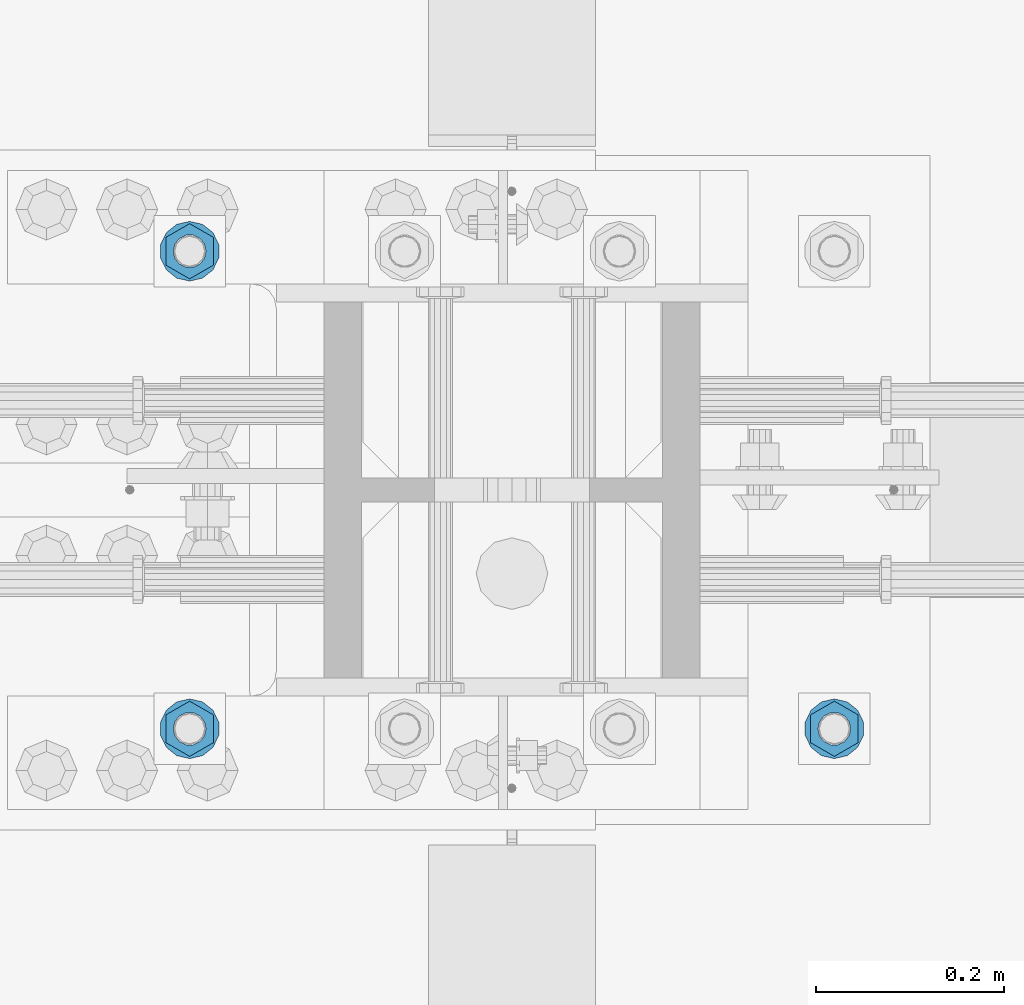
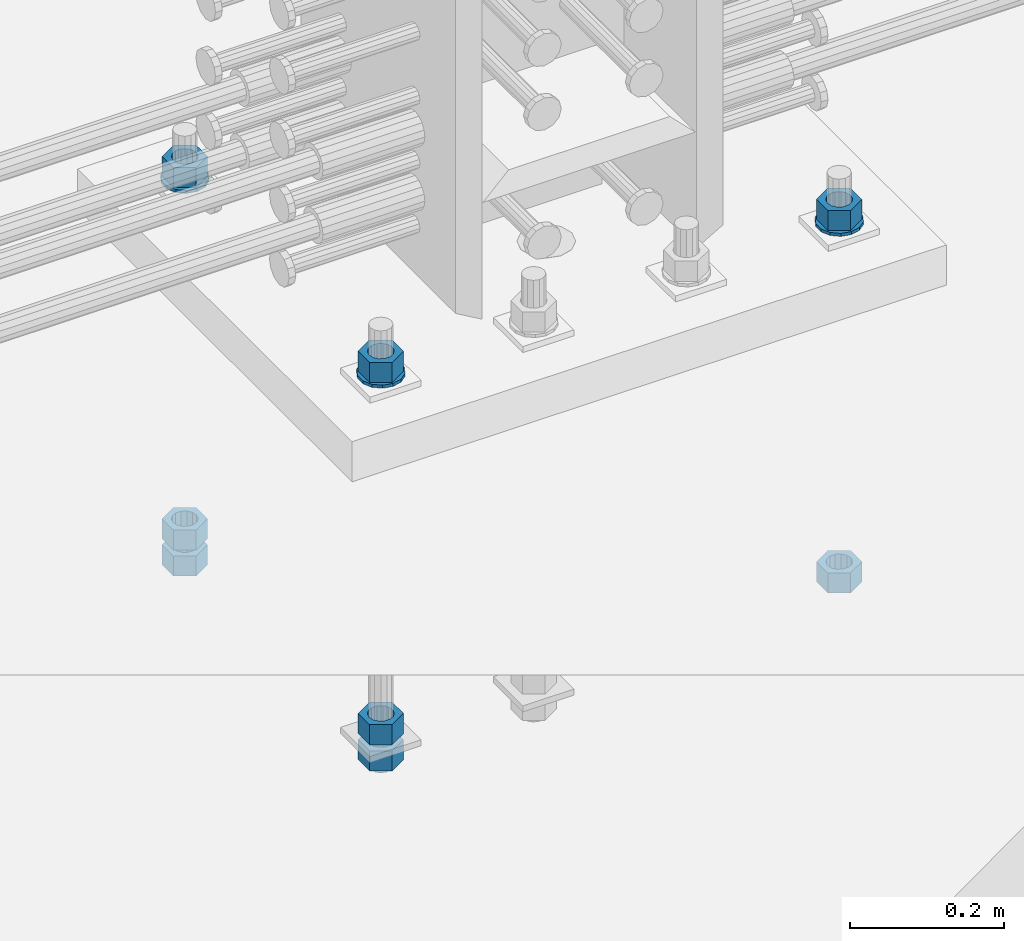
# One storey, part 1003 of 1763: 11 columns, 1 element without a shape of its own.
"""IFC2X3 building model written with IfcOpenShell, lengths in millimetres."""

from ifc_helpers import new_model, si_unit, frame, origin_with_axes, place, context, subcontext, project, spatial, faceted_brep, material, type_object, element, aggregate, save


model = new_model("IFC2X3")

# Units and contexts
model_context = context("Model", 3, precision=1e-05, world=origin_with_axes())
body_context = subcontext(model_context, "Body", "Model", "MODEL_VIEW")
ifc_project = project(units=[si_unit("LENGTHUNIT", "METRE", prefix="MILLI"), si_unit("AREAUNIT", "SQUARE_METRE"), si_unit("VOLUMEUNIT", "CUBIC_METRE"), si_unit("MASSUNIT", "GRAM", prefix="KILO"), si_unit("TIMEUNIT", "SECOND"), si_unit("PLANEANGLEUNIT", "RADIAN"), si_unit("SOLIDANGLEUNIT", "STERADIAN"), si_unit("THERMODYNAMICTEMPERATUREUNIT", "DEGREE_CELSIUS"), si_unit("LUMINOUSINTENSITYUNIT", "LUMEN")], contexts=[model_context])

# Site, building, storey
site_placement = place(None, origin_with_axes())
site = spatial("IfcSite", under=ifc_project, at=site_placement, CompositionType="ELEMENT")
building_placement = place(site_placement, origin_with_axes())
building = spatial("IfcBuilding", under=site, at=building_placement, Name="Undefined", CompositionType="ELEMENT")
storey_placement = place(building_placement, origin_with_axes())
storey = spatial("IfcBuildingStorey", under=building, at=storey_placement, Name="Undefined", CompositionType="ELEMENT", Elevation=0.0)

# Assembly, columns
assembly_placement = place(storey_placement, origin_with_axes())
assembly = element("IfcElementAssembly", 1, at=assembly_placement, inside=storey, Name="TEMPLATE", AssemblyPlace="NOTDEFINED", PredefinedType="RIGID_FRAME")
ifc_material_1 = material(Name="STEEL/A563")
column_type_1 = type_object("IfcColumnType", Name="1-1/4_HEAVY_HEX_NUT", PredefinedType="NOTDEFINED")
column_1_placement = place(assembly_placement, frame((-34606.937273698, 203.199999999951, 3957.6375), z_axis=(1.0, 0.0, 0.0), x_axis=(0.0, 0.0, -1.0)))
column_1 = element("IfcColumn", 2, at=column_1_placement, type_object=column_type_1, material=ifc_material_1, Name="NUT", ObjectType="1-1/4_HEAVY_HEX_NUT", context=body_context, shape_type="Brep", body=[
    faceted_brep([(0.0, -29.3700008392334, 0.0), (0.0, -14.6800003051758, -25.4300003051758), (31.75, -14.6800003051758, -25.4300003051758), (31.75, -29.3700008392334, 0.0), (0.0, 14.6800003051758, -25.4300003051758), (31.75, 14.6800003051758, -25.4300003051758), (0.0, 29.3700008392334, 0.0), (31.75, 29.3700008392334, 0.0), (0.0, 14.6800003051758, 25.4300003051758), (31.75, 14.6800003051758, 25.4300003051758), (0.0, -14.6800003051758, 25.4300003051758), (31.75, -14.6800003051758, 25.4300003051758), (0.0, 0.0, 17.4599990844727), (0.0, 7.57560968776022, 15.730915608714), (31.75, 7.57560968775942, 15.7309156087145), (31.75, 0.0, 17.4599990844727), (0.0, 13.6507769681037, 10.8861313696252), (31.75, 13.6507769681048, 10.8861313696314), (0.0, 17.0222404541215, 3.88521530314756), (31.75, 17.02224045412, 3.88521530315316), (0.0, 17.0222404541215, -3.88521530314756), (31.75, 17.02224045412, -3.88521530315332), (0.0, 13.6507769681037, -10.8861313696252), (31.75, 13.6507769681048, -10.8861313696316), (0.0, 7.57560968776022, -15.730915608714), (31.75, 7.57560968775942, -15.7309156087146), (0.0, 0.0, -17.4599990844727), (31.75, 0.0, -17.4599990844727), (0.0, -7.57560968776022, -15.730915608714), (31.75, -7.57560968775942, -15.7309156087145), (0.0, -13.6507769681037, -10.8861313696252), (31.75, -13.6507769681048, -10.8861313696314), (0.0, -17.0222404541215, -3.88521530314756), (31.75, -17.02224045412, -3.88521530315316), (0.0, -17.0222404541215, 3.88521530314756), (31.75, -17.02224045412, 3.88521530315332), (0.0, -13.6507769681037, 10.8861313696252), (31.75, -13.6507769681048, 10.8861313696316), (0.0, -7.57560968776022, 15.730915608714), (31.75, -7.57560968775942, 15.7309156087146)], [[[0, 1, 2, 3]], [[1, 4, 5, 2]], [[4, 6, 7, 5]], [[6, 8, 9, 7]], [[8, 10, 11, 9]], [[10, 0, 3, 11]], [[12, 13, 14, 15]], [[13, 16, 17, 14]], [[16, 18, 19, 17]], [[18, 20, 21, 19]], [[20, 22, 23, 21]], [[22, 24, 25, 23]], [[24, 26, 27, 25]], [[26, 28, 29, 27]], [[28, 30, 31, 29]], [[30, 32, 33, 31]], [[32, 34, 35, 33]], [[34, 36, 37, 35]], [[36, 38, 39, 37]], [[38, 12, 15, 39]], [[5, 7, 9, 11, 3, 2], [17, 19, 21, 23, 25, 27, 29, 31, 33, 35, 37, 39, 15, 14]], [[10, 8, 6, 4, 1, 0], [38, 36, 34, 32, 30, 28, 26, 24, 22, 20, 18, 16, 13, 12]]]),
])
column_2_placement = place(assembly_placement, frame((-34606.937273698, 203.199999999951, 3384.55), z_axis=(1.0, 0.0, 0.0), x_axis=(0.0, 0.0, -1.0)))
column_2 = element("IfcColumn", 3, at=column_2_placement, type_object=column_type_1, material=ifc_material_1, Name="NUT", ObjectType="1-1/4_HEAVY_HEX_NUT", context=body_context, shape_type="Brep", body=[
    faceted_brep([(0.0, -29.3700008392334, 0.0), (0.0, -14.6800003051758, -25.4300003051758), (31.75, -14.6800003051758, -25.4300003051758), (31.75, -29.3700008392334, 0.0), (0.0, 14.6800003051758, -25.4300003051758), (31.75, 14.6800003051758, -25.4300003051758), (0.0, 29.3700008392334, 0.0), (31.75, 29.3700008392334, 0.0), (0.0, 14.6800003051758, 25.4300003051758), (31.75, 14.6800003051758, 25.4300003051758), (0.0, -14.6800003051758, 25.4300003051758), (31.75, -14.6800003051758, 25.4300003051758), (0.0, 0.0, 17.4599990844727), (0.0, 7.57560968776022, 15.730915608714), (31.75, 7.57560968775942, 15.7309156087145), (31.75, 0.0, 17.4599990844727), (0.0, 13.6507769681037, 10.8861313696252), (31.75, 13.6507769681048, 10.8861313696314), (0.0, 17.0222404541215, 3.88521530314756), (31.75, 17.02224045412, 3.88521530315316), (0.0, 17.0222404541215, -3.88521530314756), (31.75, 17.02224045412, -3.88521530315332), (0.0, 13.6507769681037, -10.8861313696252), (31.75, 13.6507769681048, -10.8861313696316), (0.0, 7.57560968776022, -15.730915608714), (31.75, 7.57560968775942, -15.7309156087146), (0.0, 0.0, -17.4599990844727), (31.75, 0.0, -17.4599990844727), (0.0, -7.57560968776022, -15.730915608714), (31.75, -7.57560968775942, -15.7309156087145), (0.0, -13.6507769681037, -10.8861313696252), (31.75, -13.6507769681048, -10.8861313696314), (0.0, -17.0222404541215, -3.88521530314756), (31.75, -17.02224045412, -3.88521530315316), (0.0, -17.0222404541215, 3.88521530314756), (31.75, -17.02224045412, 3.88521530315332), (0.0, -13.6507769681037, 10.8861313696252), (31.75, -13.6507769681048, 10.8861313696316), (0.0, -7.57560968776022, 15.730915608714), (31.75, -7.57560968775942, 15.7309156087146)], [[[0, 1, 2, 3]], [[1, 4, 5, 2]], [[4, 6, 7, 5]], [[6, 8, 9, 7]], [[8, 10, 11, 9]], [[10, 0, 3, 11]], [[12, 13, 14, 15]], [[13, 16, 17, 14]], [[16, 18, 19, 17]], [[18, 20, 21, 19]], [[20, 22, 23, 21]], [[22, 24, 25, 23]], [[24, 26, 27, 25]], [[26, 28, 29, 27]], [[28, 30, 31, 29]], [[30, 32, 33, 31]], [[32, 34, 35, 33]], [[34, 36, 37, 35]], [[36, 38, 39, 37]], [[38, 12, 15, 39]], [[5, 7, 9, 11, 3, 2], [17, 19, 21, 23, 25, 27, 29, 31, 33, 35, 37, 39, 15, 14]], [[10, 8, 6, 4, 1, 0], [38, 36, 34, 32, 30, 28, 26, 24, 22, 20, 18, 16, 13, 12]]]),
])
column_3_placement = place(assembly_placement, frame((-35292.737273698, 203.199999999951, 3957.6375), z_axis=(1.0, 0.0, 0.0), x_axis=(0.0, 0.0, -1.0)))
column_3 = element("IfcColumn", 4, at=column_3_placement, type_object=column_type_1, material=ifc_material_1, Name="NUT", ObjectType="1-1/4_HEAVY_HEX_NUT", context=body_context, shape_type="Brep", body=[
    faceted_brep([(0.0, -29.3700008392334, 0.0), (0.0, -14.6800003051758, -25.4300003051758), (31.75, -14.6800003051758, -25.4300003051758), (31.75, -29.3700008392334, 0.0), (0.0, 14.6800003051758, -25.4300003051758), (31.75, 14.6800003051758, -25.4300003051758), (0.0, 29.3700008392334, 0.0), (31.75, 29.3700008392334, 0.0), (0.0, 14.6800003051758, 25.4300003051758), (31.75, 14.6800003051758, 25.4300003051758), (0.0, -14.6800003051758, 25.4300003051758), (31.75, -14.6800003051758, 25.4300003051758), (0.0, 0.0, 17.4599990844727), (0.0, 7.57560968776022, 15.730915608714), (31.75, 7.57560968775942, 15.7309156087145), (31.75, 0.0, 17.4599990844727), (0.0, 13.6507769681037, 10.8861313696252), (31.75, 13.6507769681048, 10.8861313696314), (0.0, 17.0222404541215, 3.88521530314756), (31.75, 17.02224045412, 3.88521530315316), (0.0, 17.0222404541215, -3.88521530314756), (31.75, 17.02224045412, -3.88521530315332), (0.0, 13.6507769681037, -10.8861313696252), (31.75, 13.6507769681048, -10.8861313696316), (0.0, 7.57560968776022, -15.730915608714), (31.75, 7.57560968775942, -15.7309156087146), (0.0, 0.0, -17.4599990844727), (31.75, 0.0, -17.4599990844727), (0.0, -7.57560968776022, -15.730915608714), (31.75, -7.57560968775942, -15.7309156087145), (0.0, -13.6507769681037, -10.8861313696252), (31.75, -13.6507769681048, -10.8861313696314), (0.0, -17.0222404541215, -3.88521530314756), (31.75, -17.02224045412, -3.88521530315316), (0.0, -17.0222404541215, 3.88521530314756), (31.75, -17.02224045412, 3.88521530315332), (0.0, -13.6507769681037, 10.8861313696252), (31.75, -13.6507769681048, 10.8861313696316), (0.0, -7.57560968776022, 15.730915608714), (31.75, -7.57560968775942, 15.7309156087146)], [[[0, 1, 2, 3]], [[1, 4, 5, 2]], [[4, 6, 7, 5]], [[6, 8, 9, 7]], [[8, 10, 11, 9]], [[10, 0, 3, 11]], [[12, 13, 14, 15]], [[13, 16, 17, 14]], [[16, 18, 19, 17]], [[18, 20, 21, 19]], [[20, 22, 23, 21]], [[22, 24, 25, 23]], [[24, 26, 27, 25]], [[26, 28, 29, 27]], [[28, 30, 31, 29]], [[30, 32, 33, 31]], [[32, 34, 35, 33]], [[34, 36, 37, 35]], [[36, 38, 39, 37]], [[38, 12, 15, 39]], [[5, 7, 9, 11, 3, 2], [17, 19, 21, 23, 25, 27, 29, 31, 33, 35, 37, 39, 15, 14]], [[10, 8, 6, 4, 1, 0], [38, 36, 34, 32, 30, 28, 26, 24, 22, 20, 18, 16, 13, 12]]]),
])
column_4_placement = place(assembly_placement, frame((-35292.737273698, 203.199999999951, 3384.55), z_axis=(1.0, 0.0, 0.0), x_axis=(0.0, 0.0, -1.0)))
column_4 = element("IfcColumn", 5, at=column_4_placement, type_object=column_type_1, material=ifc_material_1, Name="NUT", ObjectType="1-1/4_HEAVY_HEX_NUT", context=body_context, shape_type="Brep", body=[
    faceted_brep([(0.0, -29.3700008392334, 0.0), (0.0, -14.6800003051758, -25.4300003051758), (31.75, -14.6800003051758, -25.4300003051758), (31.75, -29.3700008392334, 0.0), (0.0, 14.6800003051758, -25.4300003051758), (31.75, 14.6800003051758, -25.4300003051758), (0.0, 29.3700008392334, 0.0), (31.75, 29.3700008392334, 0.0), (0.0, 14.6800003051758, 25.4300003051758), (31.75, 14.6800003051758, 25.4300003051758), (0.0, -14.6800003051758, 25.4300003051758), (31.75, -14.6800003051758, 25.4300003051758), (0.0, 0.0, 17.4599990844727), (0.0, 7.57560968776022, 15.730915608714), (31.75, 7.57560968775942, 15.7309156087145), (31.75, 0.0, 17.4599990844727), (0.0, 13.6507769681037, 10.8861313696252), (31.75, 13.6507769681048, 10.8861313696314), (0.0, 17.0222404541215, 3.88521530314756), (31.75, 17.02224045412, 3.88521530315316), (0.0, 17.0222404541215, -3.88521530314756), (31.75, 17.02224045412, -3.88521530315332), (0.0, 13.6507769681037, -10.8861313696252), (31.75, 13.6507769681048, -10.8861313696316), (0.0, 7.57560968776022, -15.730915608714), (31.75, 7.57560968775942, -15.7309156087146), (0.0, 0.0, -17.4599990844727), (31.75, 0.0, -17.4599990844727), (0.0, -7.57560968776022, -15.730915608714), (31.75, -7.57560968775942, -15.7309156087145), (0.0, -13.6507769681037, -10.8861313696252), (31.75, -13.6507769681048, -10.8861313696314), (0.0, -17.0222404541215, -3.88521530314756), (31.75, -17.02224045412, -3.88521530315316), (0.0, -17.0222404541215, 3.88521530314756), (31.75, -17.02224045412, 3.88521530315332), (0.0, -13.6507769681037, 10.8861313696252), (31.75, -13.6507769681048, 10.8861313696316), (0.0, -7.57560968776022, 15.730915608714), (31.75, -7.57560968775942, 15.7309156087146)], [[[0, 1, 2, 3]], [[1, 4, 5, 2]], [[4, 6, 7, 5]], [[6, 8, 9, 7]], [[8, 10, 11, 9]], [[10, 0, 3, 11]], [[12, 13, 14, 15]], [[13, 16, 17, 14]], [[16, 18, 19, 17]], [[18, 20, 21, 19]], [[20, 22, 23, 21]], [[22, 24, 25, 23]], [[24, 26, 27, 25]], [[26, 28, 29, 27]], [[28, 30, 31, 29]], [[30, 32, 33, 31]], [[32, 34, 35, 33]], [[34, 36, 37, 35]], [[36, 38, 39, 37]], [[38, 12, 15, 39]], [[5, 7, 9, 11, 3, 2], [17, 19, 21, 23, 25, 27, 29, 31, 33, 35, 37, 39, 15, 14]], [[10, 8, 6, 4, 1, 0], [38, 36, 34, 32, 30, 28, 26, 24, 22, 20, 18, 16, 13, 12]]]),
])
column_5_placement = place(assembly_placement, frame((-35292.737273698, 203.199999999951, 3343.275), z_axis=(1.0, 0.0, 0.0), x_axis=(0.0, 0.0, -1.0)))
column_5 = element("IfcColumn", 6, at=column_5_placement, type_object=column_type_1, material=ifc_material_1, Name="NUT", ObjectType="1-1/4_HEAVY_HEX_NUT", context=body_context, shape_type="Brep", body=[
    faceted_brep([(0.0, -29.3700008392334, 0.0), (0.0, -14.6800003051758, -25.4300003051758), (31.75, -14.6800003051758, -25.4300003051758), (31.75, -29.3700008392334, 0.0), (0.0, 14.6800003051758, -25.4300003051758), (31.75, 14.6800003051758, -25.4300003051758), (0.0, 29.3700008392334, 0.0), (31.75, 29.3700008392334, 0.0), (0.0, 14.6800003051758, 25.4300003051758), (31.75, 14.6800003051758, 25.4300003051758), (0.0, -14.6800003051758, 25.4300003051758), (31.75, -14.6800003051758, 25.4300003051758), (0.0, 0.0, 17.4599990844727), (0.0, 7.57560968776022, 15.730915608714), (31.75, 7.57560968775942, 15.7309156087145), (31.75, 0.0, 17.4599990844727), (0.0, 13.6507769681037, 10.8861313696252), (31.75, 13.6507769681048, 10.8861313696314), (0.0, 17.0222404541215, 3.88521530314756), (31.75, 17.02224045412, 3.88521530315316), (0.0, 17.0222404541215, -3.88521530314756), (31.75, 17.02224045412, -3.88521530315332), (0.0, 13.6507769681037, -10.8861313696252), (31.75, 13.6507769681048, -10.8861313696316), (0.0, 7.57560968776022, -15.730915608714), (31.75, 7.57560968775942, -15.7309156087146), (0.0, 0.0, -17.4599990844727), (31.75, 0.0, -17.4599990844727), (0.0, -7.57560968776022, -15.730915608714), (31.75, -7.57560968775942, -15.7309156087145), (0.0, -13.6507769681037, -10.8861313696252), (31.75, -13.6507769681048, -10.8861313696314), (0.0, -17.0222404541215, -3.88521530314756), (31.75, -17.02224045412, -3.88521530315316), (0.0, -17.0222404541215, 3.88521530314756), (31.75, -17.02224045412, 3.88521530315332), (0.0, -13.6507769681037, 10.8861313696252), (31.75, -13.6507769681048, 10.8861313696316), (0.0, -7.57560968776022, 15.730915608714), (31.75, -7.57560968775942, 15.7309156087146)], [[[0, 1, 2, 3]], [[1, 4, 5, 2]], [[4, 6, 7, 5]], [[6, 8, 9, 7]], [[8, 10, 11, 9]], [[10, 0, 3, 11]], [[12, 13, 14, 15]], [[13, 16, 17, 14]], [[16, 18, 19, 17]], [[18, 20, 21, 19]], [[20, 22, 23, 21]], [[22, 24, 25, 23]], [[24, 26, 27, 25]], [[26, 28, 29, 27]], [[28, 30, 31, 29]], [[30, 32, 33, 31]], [[32, 34, 35, 33]], [[34, 36, 37, 35]], [[36, 38, 39, 37]], [[38, 12, 15, 39]], [[5, 7, 9, 11, 3, 2], [17, 19, 21, 23, 25, 27, 29, 31, 33, 35, 37, 39, 15, 14]], [[10, 8, 6, 4, 1, 0], [38, 36, 34, 32, 30, 28, 26, 24, 22, 20, 18, 16, 13, 12]]]),
])
column_6_placement = place(assembly_placement, frame((-35292.737273698, 711.199999999951, 3957.6375), z_axis=(-1.0, 0.0, 0.0), x_axis=(0.0, 0.0, -1.0)))
column_6 = element("IfcColumn", 7, at=column_6_placement, type_object=column_type_1, material=ifc_material_1, Name="NUT", ObjectType="1-1/4_HEAVY_HEX_NUT", context=body_context, shape_type="Brep", body=[
    faceted_brep([(0.0, -29.3700008392334, 0.0), (0.0, -14.6800003051758, -25.4300003051758), (31.75, -14.6800003051758, -25.4300003051758), (31.75, -29.3700008392334, 0.0), (0.0, 14.6800003051758, -25.4300003051758), (31.75, 14.6800003051758, -25.4300003051758), (0.0, 29.3700008392334, 0.0), (31.75, 29.3700008392334, 0.0), (0.0, 14.6800003051758, 25.4300003051758), (31.75, 14.6800003051758, 25.4300003051758), (0.0, -14.6800003051758, 25.4300003051758), (31.75, -14.6800003051758, 25.4300003051758), (0.0, 0.0, 17.4599990844727), (0.0, 7.57560968776022, 15.730915608714), (31.75, 7.57560968775942, 15.7309156087145), (31.75, 0.0, 17.4599990844727), (0.0, 13.6507769681037, 10.8861313696252), (31.75, 13.6507769681048, 10.8861313696314), (0.0, 17.0222404541215, 3.88521530314756), (31.75, 17.02224045412, 3.88521530315316), (0.0, 17.0222404541215, -3.88521530314756), (31.75, 17.02224045412, -3.88521530315332), (0.0, 13.6507769681037, -10.8861313696252), (31.75, 13.6507769681048, -10.8861313696316), (0.0, 7.57560968776022, -15.730915608714), (31.75, 7.57560968775942, -15.7309156087146), (0.0, 0.0, -17.4599990844727), (31.75, 0.0, -17.4599990844727), (0.0, -7.57560968776022, -15.730915608714), (31.75, -7.57560968775942, -15.7309156087145), (0.0, -13.6507769681037, -10.8861313696252), (31.75, -13.6507769681048, -10.8861313696314), (0.0, -17.0222404541215, -3.88521530314756), (31.75, -17.02224045412, -3.88521530315316), (0.0, -17.0222404541215, 3.88521530314756), (31.75, -17.02224045412, 3.88521530315332), (0.0, -13.6507769681037, 10.8861313696252), (31.75, -13.6507769681048, 10.8861313696316), (0.0, -7.57560968776022, 15.730915608714), (31.75, -7.57560968775942, 15.7309156087146)], [[[0, 1, 2, 3]], [[1, 4, 5, 2]], [[4, 6, 7, 5]], [[6, 8, 9, 7]], [[8, 10, 11, 9]], [[10, 0, 3, 11]], [[12, 13, 14, 15]], [[13, 16, 17, 14]], [[16, 18, 19, 17]], [[18, 20, 21, 19]], [[20, 22, 23, 21]], [[22, 24, 25, 23]], [[24, 26, 27, 25]], [[26, 28, 29, 27]], [[28, 30, 31, 29]], [[30, 32, 33, 31]], [[32, 34, 35, 33]], [[34, 36, 37, 35]], [[36, 38, 39, 37]], [[38, 12, 15, 39]], [[5, 7, 9, 11, 3, 2], [17, 19, 21, 23, 25, 27, 29, 31, 33, 35, 37, 39, 15, 14]], [[10, 8, 6, 4, 1, 0], [38, 36, 34, 32, 30, 28, 26, 24, 22, 20, 18, 16, 13, 12]]]),
])
column_7_placement = place(assembly_placement, frame((-35292.737273698, 711.199999999951, 3384.55), z_axis=(-1.0, 0.0, 0.0), x_axis=(0.0, 0.0, -1.0)))
column_7 = element("IfcColumn", 8, at=column_7_placement, type_object=column_type_1, material=ifc_material_1, Name="NUT", ObjectType="1-1/4_HEAVY_HEX_NUT", context=body_context, shape_type="Brep", body=[
    faceted_brep([(0.0, -29.3700008392334, 0.0), (0.0, -14.6800003051758, -25.4300003051758), (31.75, -14.6800003051758, -25.4300003051758), (31.75, -29.3700008392334, 0.0), (0.0, 14.6800003051758, -25.4300003051758), (31.75, 14.6800003051758, -25.4300003051758), (0.0, 29.3700008392334, 0.0), (31.75, 29.3700008392334, 0.0), (0.0, 14.6800003051758, 25.4300003051758), (31.75, 14.6800003051758, 25.4300003051758), (0.0, -14.6800003051758, 25.4300003051758), (31.75, -14.6800003051758, 25.4300003051758), (0.0, 0.0, 17.4599990844727), (0.0, 7.57560968776022, 15.730915608714), (31.75, 7.57560968775942, 15.7309156087145), (31.75, 0.0, 17.4599990844727), (0.0, 13.6507769681037, 10.8861313696252), (31.75, 13.6507769681048, 10.8861313696314), (0.0, 17.0222404541215, 3.88521530314756), (31.75, 17.02224045412, 3.88521530315316), (0.0, 17.0222404541215, -3.88521530314756), (31.75, 17.02224045412, -3.88521530315332), (0.0, 13.6507769681037, -10.8861313696252), (31.75, 13.6507769681048, -10.8861313696316), (0.0, 7.57560968776022, -15.730915608714), (31.75, 7.57560968775942, -15.7309156087146), (0.0, 0.0, -17.4599990844727), (31.75, 0.0, -17.4599990844727), (0.0, -7.57560968776022, -15.730915608714), (31.75, -7.57560968775942, -15.7309156087145), (0.0, -13.6507769681037, -10.8861313696252), (31.75, -13.6507769681048, -10.8861313696314), (0.0, -17.0222404541215, -3.88521530314756), (31.75, -17.02224045412, -3.88521530315316), (0.0, -17.0222404541215, 3.88521530314756), (31.75, -17.02224045412, 3.88521530315332), (0.0, -13.6507769681037, 10.8861313696252), (31.75, -13.6507769681048, 10.8861313696316), (0.0, -7.57560968776022, 15.730915608714), (31.75, -7.57560968775942, 15.7309156087146)], [[[0, 1, 2, 3]], [[1, 4, 5, 2]], [[4, 6, 7, 5]], [[6, 8, 9, 7]], [[8, 10, 11, 9]], [[10, 0, 3, 11]], [[12, 13, 14, 15]], [[13, 16, 17, 14]], [[16, 18, 19, 17]], [[18, 20, 21, 19]], [[20, 22, 23, 21]], [[22, 24, 25, 23]], [[24, 26, 27, 25]], [[26, 28, 29, 27]], [[28, 30, 31, 29]], [[30, 32, 33, 31]], [[32, 34, 35, 33]], [[34, 36, 37, 35]], [[36, 38, 39, 37]], [[38, 12, 15, 39]], [[5, 7, 9, 11, 3, 2], [17, 19, 21, 23, 25, 27, 29, 31, 33, 35, 37, 39, 15, 14]], [[10, 8, 6, 4, 1, 0], [38, 36, 34, 32, 30, 28, 26, 24, 22, 20, 18, 16, 13, 12]]]),
])
column_8_placement = place(assembly_placement, frame((-35292.737273698, 711.199999999951, 3343.275), z_axis=(-1.0, 0.0, 0.0), x_axis=(0.0, 0.0, -1.0)))
column_8 = element("IfcColumn", 9, at=column_8_placement, type_object=column_type_1, material=ifc_material_1, Name="NUT", ObjectType="1-1/4_HEAVY_HEX_NUT", context=body_context, shape_type="Brep", body=[
    faceted_brep([(0.0, -29.3700008392334, 0.0), (0.0, -14.6800003051758, -25.4300003051758), (31.75, -14.6800003051758, -25.4300003051758), (31.75, -29.3700008392334, 0.0), (0.0, 14.6800003051758, -25.4300003051758), (31.75, 14.6800003051758, -25.4300003051758), (0.0, 29.3700008392334, 0.0), (31.75, 29.3700008392334, 0.0), (0.0, 14.6800003051758, 25.4300003051758), (31.75, 14.6800003051758, 25.4300003051758), (0.0, -14.6800003051758, 25.4300003051758), (31.75, -14.6800003051758, 25.4300003051758), (0.0, 0.0, 17.4599990844727), (0.0, 7.57560968776022, 15.730915608714), (31.75, 7.57560968775942, 15.7309156087145), (31.75, 0.0, 17.4599990844727), (0.0, 13.6507769681037, 10.8861313696252), (31.75, 13.6507769681048, 10.8861313696314), (0.0, 17.0222404541215, 3.88521530314756), (31.75, 17.02224045412, 3.88521530315316), (0.0, 17.0222404541215, -3.88521530314756), (31.75, 17.02224045412, -3.88521530315332), (0.0, 13.6507769681037, -10.8861313696252), (31.75, 13.6507769681048, -10.8861313696316), (0.0, 7.57560968776022, -15.730915608714), (31.75, 7.57560968775942, -15.7309156087146), (0.0, 0.0, -17.4599990844727), (31.75, 0.0, -17.4599990844727), (0.0, -7.57560968776022, -15.730915608714), (31.75, -7.57560968775942, -15.7309156087145), (0.0, -13.6507769681037, -10.8861313696252), (31.75, -13.6507769681048, -10.8861313696314), (0.0, -17.0222404541215, -3.88521530314756), (31.75, -17.02224045412, -3.88521530315316), (0.0, -17.0222404541215, 3.88521530314756), (31.75, -17.02224045412, 3.88521530315332), (0.0, -13.6507769681037, 10.8861313696252), (31.75, -13.6507769681048, 10.8861313696316), (0.0, -7.57560968776022, 15.730915608714), (31.75, -7.57560968775942, 15.7309156087146)], [[[0, 1, 2, 3]], [[1, 4, 5, 2]], [[4, 6, 7, 5]], [[6, 8, 9, 7]], [[8, 10, 11, 9]], [[10, 0, 3, 11]], [[12, 13, 14, 15]], [[13, 16, 17, 14]], [[16, 18, 19, 17]], [[18, 20, 21, 19]], [[20, 22, 23, 21]], [[22, 24, 25, 23]], [[24, 26, 27, 25]], [[26, 28, 29, 27]], [[28, 30, 31, 29]], [[30, 32, 33, 31]], [[32, 34, 35, 33]], [[34, 36, 37, 35]], [[36, 38, 39, 37]], [[38, 12, 15, 39]], [[5, 7, 9, 11, 3, 2], [17, 19, 21, 23, 25, 27, 29, 31, 33, 35, 37, 39, 15, 14]], [[10, 8, 6, 4, 1, 0], [38, 36, 34, 32, 30, 28, 26, 24, 22, 20, 18, 16, 13, 12]]]),
])
ifc_material_2 = material(Name="STEEL/F436")
column_type_2 = type_object("IfcColumnType", Name="1-1/4_WASHER", PredefinedType="NOTDEFINED")
column_9_placement = place(assembly_placement, frame((-34606.937273698, 203.199999999951, 3925.8875), z_axis=(1.0, 0.0, 0.0), x_axis=(0.0, 0.0, -1.0)))
column_9 = element("IfcColumn", 10, at=column_9_placement, type_object=column_type_2, material=ifc_material_2, Name="WASHER", ObjectType="1-1/4_WASHER", context=body_context, shape_type="Brep", body=[
    faceted_brep([(-4.54747350886464e-13, -31.7499999999964, 0.0), (0.0, -28.6057615559002, -13.7758087169827), (4.76249999999982, -28.6057615559002, -13.7758087169827), (4.76249999999982, -31.75, 0.0), (0.0, -19.795801209013, -24.8231495683602), (4.76249999999982, -19.795801209013, -24.8231495683602), (0.0, -7.06503965311276, -30.9539612117732), (4.76249999999982, -7.06503965311276, -30.9539612117732), (0.0, 7.06503965311276, -30.9539612117732), (4.76249999999982, 7.06503965311276, -30.9539612117732), (0.0, 19.7958012090166, -24.8231495683602), (4.76249999999982, 19.7958012090166, -24.8231495683602), (0.0, 28.6057615559039, -13.7758087169827), (4.76249999999982, 28.6057615559039, -13.7758087169827), (-5.91171556152403e-12, 31.7499999999891, 0.0), (4.76249999999982, 31.75, 0.0), (0.0, 28.6057615559002, 13.7758087169827), (4.76249999999982, 28.6057615559002, 13.7758087169827), (0.0, 19.795801209013, 24.8231495683602), (4.76249999999982, 19.795801209013, 24.8231495683602), (0.0, 7.06503965311276, 30.9539612117731), (4.76249999999982, 7.06503965311276, 30.9539612117731), (0.0, -7.06503965311276, 30.9539612117731), (4.76249999999982, -7.06503965311276, 30.9539612117731), (0.0, -19.7958012090166, 24.8231495683602), (4.76249999999982, -19.7958012090166, 24.8231495683602), (0.0, -28.6057615559039, 13.7758087169827), (4.76249999999982, -28.6057615559039, 13.7758087169827), (0.0, 0.0, 17.4599990844727), (0.0, 7.57560968776022, 15.730915608714), (4.76249999999982, 7.57560968775942, 15.7309156087145), (4.76249999999982, 0.0, 17.4599990844727), (0.0, 13.6507769681037, 10.8861313696252), (4.76249999999982, 13.6507769681048, 10.8861313696314), (0.0, 17.0222404541215, 3.88521530314756), (4.76249999999982, 17.02224045412, 3.88521530315316), (0.0, 17.0222404541215, -3.88521530314756), (4.76249999999982, 17.02224045412, -3.88521530315332), (0.0, 13.6507769681037, -10.8861313696252), (4.76249999999982, 13.6507769681048, -10.8861313696316), (0.0, 7.57560968776022, -15.730915608714), (4.76249999999982, 7.57560968775942, -15.7309156087146), (0.0, 0.0, -17.4599990844727), (4.76249999999982, 0.0, -17.4599990844727), (0.0, -7.57560968776022, -15.730915608714), (4.76249999999982, -7.57560968775942, -15.7309156087145), (0.0, -13.6507769681037, -10.8861313696252), (4.76249999999982, -13.6507769681048, -10.8861313696314), (0.0, -17.0222404541215, -3.88521530314756), (4.76249999999982, -17.02224045412, -3.88521530315316), (0.0, -17.0222404541215, 3.88521530314756), (4.76249999999982, -17.02224045412, 3.88521530315332), (0.0, -13.6507769681037, 10.8861313696252), (4.76249999999982, -13.6507769681048, 10.8861313696316), (0.0, -7.57560968776022, 15.730915608714), (4.76249999999982, -7.57560968775942, 15.7309156087146)], [[[0, 1, 2, 3]], [[1, 4, 5, 2]], [[4, 6, 7, 5]], [[6, 8, 9, 7]], [[8, 10, 11, 9]], [[10, 12, 13, 11]], [[12, 14, 15, 13]], [[14, 16, 17, 15]], [[16, 18, 19, 17]], [[18, 20, 21, 19]], [[20, 22, 23, 21]], [[22, 24, 25, 23]], [[24, 26, 27, 25]], [[26, 0, 3, 27]], [[28, 29, 30, 31]], [[29, 32, 33, 30]], [[32, 34, 35, 33]], [[34, 36, 37, 35]], [[36, 38, 39, 37]], [[38, 40, 41, 39]], [[40, 42, 43, 41]], [[42, 44, 45, 43]], [[44, 46, 47, 45]], [[46, 48, 49, 47]], [[48, 50, 51, 49]], [[50, 52, 53, 51]], [[52, 54, 55, 53]], [[54, 28, 31, 55]], [[5, 7, 9, 11, 13, 15, 17, 19, 21, 23, 25, 27, 3, 2], [33, 35, 37, 39, 41, 43, 45, 47, 49, 51, 53, 55, 31, 30]], [[26, 24, 22, 20, 18, 16, 14, 12, 10, 8, 6, 4, 1, 0], [54, 52, 50, 48, 46, 44, 42, 40, 38, 36, 34, 32, 29, 28]]]),
])
column_10_placement = place(assembly_placement, frame((-35292.737273698, 203.199999999951, 3925.8875), z_axis=(1.0, 0.0, 0.0), x_axis=(0.0, 0.0, -1.0)))
column_10 = element("IfcColumn", 11, at=column_10_placement, type_object=column_type_2, material=ifc_material_2, Name="WASHER", ObjectType="1-1/4_WASHER", context=body_context, shape_type="Brep", body=[
    faceted_brep([(-4.54747350886464e-13, -31.7499999999964, 0.0), (0.0, -28.6057615559002, -13.7758087169827), (4.76249999999982, -28.6057615559002, -13.7758087169827), (4.76249999999982, -31.75, 0.0), (0.0, -19.795801209013, -24.8231495683602), (4.76249999999982, -19.795801209013, -24.8231495683602), (0.0, -7.06503965311276, -30.9539612117732), (4.76249999999982, -7.06503965311276, -30.9539612117732), (0.0, 7.06503965311276, -30.9539612117732), (4.76249999999982, 7.06503965311276, -30.9539612117732), (0.0, 19.7958012090166, -24.8231495683602), (4.76249999999982, 19.7958012090166, -24.8231495683602), (0.0, 28.6057615559039, -13.7758087169827), (4.76249999999982, 28.6057615559039, -13.7758087169827), (-5.91171556152403e-12, 31.7499999999891, 0.0), (4.76249999999982, 31.75, 0.0), (0.0, 28.6057615559002, 13.7758087169827), (4.76249999999982, 28.6057615559002, 13.7758087169827), (0.0, 19.795801209013, 24.8231495683602), (4.76249999999982, 19.795801209013, 24.8231495683602), (0.0, 7.06503965311276, 30.9539612117731), (4.76249999999982, 7.06503965311276, 30.9539612117731), (0.0, -7.06503965311276, 30.9539612117731), (4.76249999999982, -7.06503965311276, 30.9539612117731), (0.0, -19.7958012090166, 24.8231495683602), (4.76249999999982, -19.7958012090166, 24.8231495683602), (0.0, -28.6057615559039, 13.7758087169827), (4.76249999999982, -28.6057615559039, 13.7758087169827), (0.0, 0.0, 17.4599990844727), (0.0, 7.57560968776022, 15.730915608714), (4.76249999999982, 7.57560968775942, 15.7309156087145), (4.76249999999982, 0.0, 17.4599990844727), (0.0, 13.6507769681037, 10.8861313696252), (4.76249999999982, 13.6507769681048, 10.8861313696314), (0.0, 17.0222404541215, 3.88521530314756), (4.76249999999982, 17.02224045412, 3.88521530315316), (0.0, 17.0222404541215, -3.88521530314756), (4.76249999999982, 17.02224045412, -3.88521530315332), (0.0, 13.6507769681037, -10.8861313696252), (4.76249999999982, 13.6507769681048, -10.8861313696316), (0.0, 7.57560968776022, -15.730915608714), (4.76249999999982, 7.57560968775942, -15.7309156087146), (0.0, 0.0, -17.4599990844727), (4.76249999999982, 0.0, -17.4599990844727), (0.0, -7.57560968776022, -15.730915608714), (4.76249999999982, -7.57560968775942, -15.7309156087145), (0.0, -13.6507769681037, -10.8861313696252), (4.76249999999982, -13.6507769681048, -10.8861313696314), (0.0, -17.0222404541215, -3.88521530314756), (4.76249999999982, -17.02224045412, -3.88521530315316), (0.0, -17.0222404541215, 3.88521530314756), (4.76249999999982, -17.02224045412, 3.88521530315332), (0.0, -13.6507769681037, 10.8861313696252), (4.76249999999982, -13.6507769681048, 10.8861313696316), (0.0, -7.57560968776022, 15.730915608714), (4.76249999999982, -7.57560968775942, 15.7309156087146)], [[[0, 1, 2, 3]], [[1, 4, 5, 2]], [[4, 6, 7, 5]], [[6, 8, 9, 7]], [[8, 10, 11, 9]], [[10, 12, 13, 11]], [[12, 14, 15, 13]], [[14, 16, 17, 15]], [[16, 18, 19, 17]], [[18, 20, 21, 19]], [[20, 22, 23, 21]], [[22, 24, 25, 23]], [[24, 26, 27, 25]], [[26, 0, 3, 27]], [[28, 29, 30, 31]], [[29, 32, 33, 30]], [[32, 34, 35, 33]], [[34, 36, 37, 35]], [[36, 38, 39, 37]], [[38, 40, 41, 39]], [[40, 42, 43, 41]], [[42, 44, 45, 43]], [[44, 46, 47, 45]], [[46, 48, 49, 47]], [[48, 50, 51, 49]], [[50, 52, 53, 51]], [[52, 54, 55, 53]], [[54, 28, 31, 55]], [[5, 7, 9, 11, 13, 15, 17, 19, 21, 23, 25, 27, 3, 2], [33, 35, 37, 39, 41, 43, 45, 47, 49, 51, 53, 55, 31, 30]], [[26, 24, 22, 20, 18, 16, 14, 12, 10, 8, 6, 4, 1, 0], [54, 52, 50, 48, 46, 44, 42, 40, 38, 36, 34, 32, 29, 28]]]),
])
column_11_placement = place(assembly_placement, frame((-35292.737273698, 711.199999999951, 3925.8875), z_axis=(-1.0, 0.0, 0.0), x_axis=(0.0, 0.0, -1.0)))
column_11 = element("IfcColumn", 12, at=column_11_placement, type_object=column_type_2, material=ifc_material_2, Name="WASHER", ObjectType="1-1/4_WASHER", context=body_context, shape_type="Brep", body=[
    faceted_brep([(-4.54747350886464e-13, -31.7499999999964, 0.0), (0.0, -28.6057615559002, -13.7758087169827), (4.76249999999982, -28.6057615559002, -13.7758087169827), (4.76249999999982, -31.75, 0.0), (0.0, -19.795801209013, -24.8231495683602), (4.76249999999982, -19.795801209013, -24.8231495683602), (0.0, -7.06503965311276, -30.9539612117732), (4.76249999999982, -7.06503965311276, -30.9539612117732), (0.0, 7.06503965311276, -30.9539612117732), (4.76249999999982, 7.06503965311276, -30.9539612117732), (0.0, 19.7958012090166, -24.8231495683602), (4.76249999999982, 19.7958012090166, -24.8231495683602), (0.0, 28.6057615559039, -13.7758087169827), (4.76249999999982, 28.6057615559039, -13.7758087169827), (-5.91171556152403e-12, 31.7499999999891, 0.0), (4.76249999999982, 31.75, 0.0), (0.0, 28.6057615559002, 13.7758087169827), (4.76249999999982, 28.6057615559002, 13.7758087169827), (0.0, 19.795801209013, 24.8231495683602), (4.76249999999982, 19.795801209013, 24.8231495683602), (0.0, 7.06503965311276, 30.9539612117731), (4.76249999999982, 7.06503965311276, 30.9539612117731), (0.0, -7.06503965311276, 30.9539612117731), (4.76249999999982, -7.06503965311276, 30.9539612117731), (0.0, -19.7958012090166, 24.8231495683602), (4.76249999999982, -19.7958012090166, 24.8231495683602), (0.0, -28.6057615559039, 13.7758087169827), (4.76249999999982, -28.6057615559039, 13.7758087169827), (0.0, 0.0, 17.4599990844727), (0.0, 7.57560968776022, 15.730915608714), (4.76249999999982, 7.57560968775942, 15.7309156087145), (4.76249999999982, 0.0, 17.4599990844727), (0.0, 13.6507769681037, 10.8861313696252), (4.76249999999982, 13.6507769681048, 10.8861313696314), (0.0, 17.0222404541215, 3.88521530314756), (4.76249999999982, 17.02224045412, 3.88521530315316), (0.0, 17.0222404541215, -3.88521530314756), (4.76249999999982, 17.02224045412, -3.88521530315332), (0.0, 13.6507769681037, -10.8861313696252), (4.76249999999982, 13.6507769681048, -10.8861313696316), (0.0, 7.57560968776022, -15.730915608714), (4.76249999999982, 7.57560968775942, -15.7309156087146), (0.0, 0.0, -17.4599990844727), (4.76249999999982, 0.0, -17.4599990844727), (0.0, -7.57560968776022, -15.730915608714), (4.76249999999982, -7.57560968775942, -15.7309156087145), (0.0, -13.6507769681037, -10.8861313696252), (4.76249999999982, -13.6507769681048, -10.8861313696314), (0.0, -17.0222404541215, -3.88521530314756), (4.76249999999982, -17.02224045412, -3.88521530315316), (0.0, -17.0222404541215, 3.88521530314756), (4.76249999999982, -17.02224045412, 3.88521530315332), (0.0, -13.6507769681037, 10.8861313696252), (4.76249999999982, -13.6507769681048, 10.8861313696316), (0.0, -7.57560968776022, 15.730915608714), (4.76249999999982, -7.57560968775942, 15.7309156087146)], [[[0, 1, 2, 3]], [[1, 4, 5, 2]], [[4, 6, 7, 5]], [[6, 8, 9, 7]], [[8, 10, 11, 9]], [[10, 12, 13, 11]], [[12, 14, 15, 13]], [[14, 16, 17, 15]], [[16, 18, 19, 17]], [[18, 20, 21, 19]], [[20, 22, 23, 21]], [[22, 24, 25, 23]], [[24, 26, 27, 25]], [[26, 0, 3, 27]], [[28, 29, 30, 31]], [[29, 32, 33, 30]], [[32, 34, 35, 33]], [[34, 36, 37, 35]], [[36, 38, 39, 37]], [[38, 40, 41, 39]], [[40, 42, 43, 41]], [[42, 44, 45, 43]], [[44, 46, 47, 45]], [[46, 48, 49, 47]], [[48, 50, 51, 49]], [[50, 52, 53, 51]], [[52, 54, 55, 53]], [[54, 28, 31, 55]], [[5, 7, 9, 11, 13, 15, 17, 19, 21, 23, 25, 27, 3, 2], [33, 35, 37, 39, 41, 43, 45, 47, 49, 51, 53, 55, 31, 30]], [[26, 24, 22, 20, 18, 16, 14, 12, 10, 8, 6, 4, 1, 0], [54, 52, 50, 48, 46, 44, 42, 40, 38, 36, 34, 32, 29, 28]]]),
])
aggregate(assembly, [column_1, column_9, column_2, column_3, column_10, column_4, column_5, column_6, column_11, column_7, column_8])

save(model, "model.ifc")
